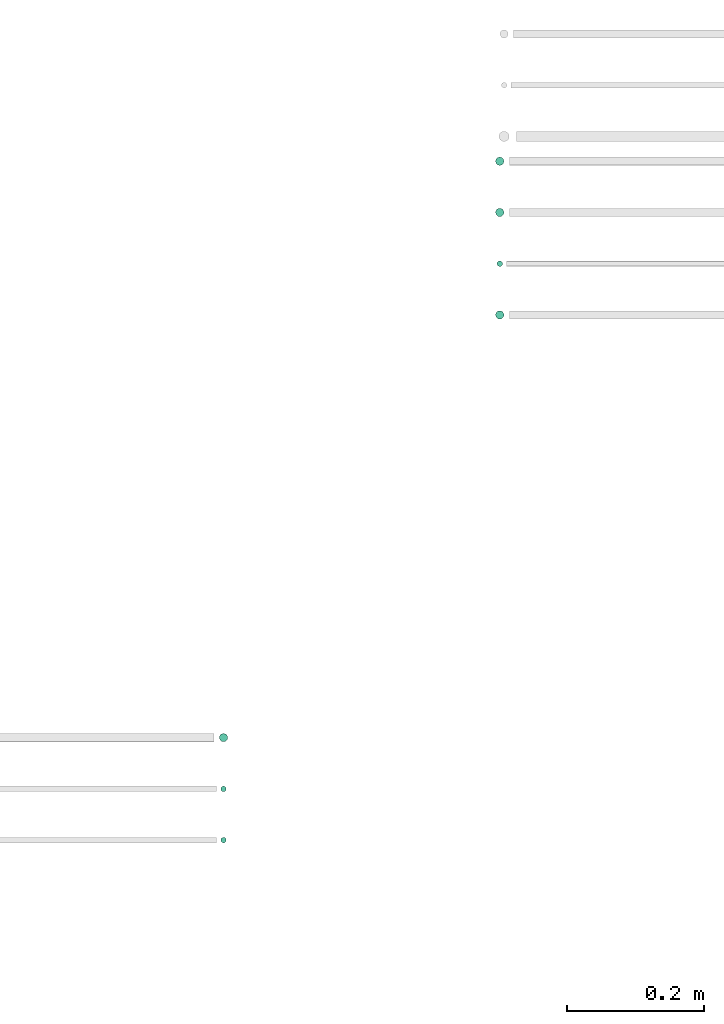
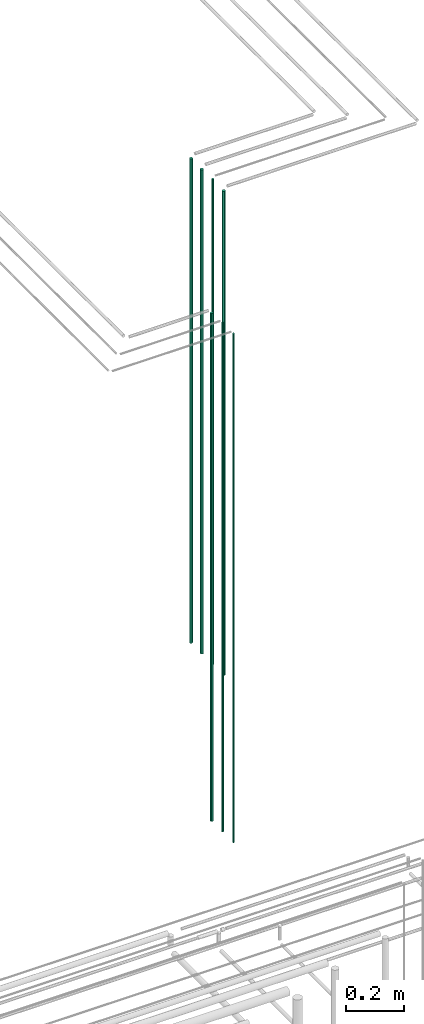
# One storey, part 67 of 331: 7 flow segments.
"""IFC2X3 building model written with IfcOpenShell, lengths in millimetres."""

from ifc_helpers import new_model, entity, si_unit, converted_unit, derived_unit, direction, frame, frame_2d, origin, origin_2d_with_axis, place, context, subcontext, project, spatial, circle, extrude, type_object, element, save


model = new_model("IFC2X3")

# Units and contexts
model_context = context("Model", 3, precision=0.01, world=origin(), true_north=direction((6.12303176911189e-17, 1.0)))
body_context = subcontext(model_context, "Body", "Model", "MODEL_VIEW")
ifc_project = project(units=[si_unit("LENGTHUNIT", "METRE", prefix="MILLI"), si_unit("AREAUNIT", "SQUARE_METRE"), si_unit("VOLUMEUNIT", "CUBIC_METRE"), converted_unit("PLANEANGLEUNIT", "DEGREE", entity("IfcRatioMeasure", 0.0174532925199433), si_unit("PLANEANGLEUNIT", "RADIAN"), dimensions=[0, 0, 0, 0, 0, 0, 0]), si_unit("MASSUNIT", "GRAM", prefix="KILO"), derived_unit("MASSDENSITYUNIT", [(si_unit("MASSUNIT", "GRAM", prefix="KILO"), 1), (si_unit("LENGTHUNIT", "METRE"), -3)]), derived_unit("MOMENTOFINERTIAUNIT", [(si_unit("LENGTHUNIT", "METRE"), 4)]), si_unit("TIMEUNIT", "SECOND"), si_unit("FREQUENCYUNIT", "HERTZ"), si_unit("THERMODYNAMICTEMPERATUREUNIT", "DEGREE_CELSIUS"), derived_unit("THERMALTRANSMITTANCEUNIT", [(si_unit("MASSUNIT", "GRAM", prefix="KILO"), 1), (si_unit("THERMODYNAMICTEMPERATUREUNIT", "KELVIN"), -1), (si_unit("TIMEUNIT", "SECOND"), -3)]), derived_unit("VOLUMETRICFLOWRATEUNIT", [(si_unit("LENGTHUNIT", "METRE"), 3), (si_unit("TIMEUNIT", "SECOND"), -1)]), derived_unit("MASSFLOWRATEUNIT", [(si_unit("MASSUNIT", "GRAM", prefix="KILO"), 1), (si_unit("TIMEUNIT", "SECOND"), -1)]), derived_unit("ROTATIONALFREQUENCYUNIT", [(si_unit("TIMEUNIT", "SECOND"), -1)]), si_unit("ELECTRICCURRENTUNIT", "AMPERE"), si_unit("ELECTRICVOLTAGEUNIT", "VOLT"), si_unit("POWERUNIT", "WATT"), si_unit("FORCEUNIT", "NEWTON", prefix="KILO"), si_unit("ILLUMINANCEUNIT", "LUX"), si_unit("LUMINOUSFLUXUNIT", "LUMEN"), si_unit("LUMINOUSINTENSITYUNIT", "CANDELA"), derived_unit("USERDEFINED", [(si_unit("MASSUNIT", "GRAM", prefix="KILO"), -1), (si_unit("LENGTHUNIT", "METRE"), -2), (si_unit("TIMEUNIT", "SECOND"), 3), (si_unit("LUMINOUSFLUXUNIT", "LUMEN"), 1)]), derived_unit("LINEARVELOCITYUNIT", [(si_unit("LENGTHUNIT", "METRE"), 1), (si_unit("TIMEUNIT", "SECOND"), -1)]), si_unit("PRESSUREUNIT", "PASCAL"), derived_unit("USERDEFINED", [(si_unit("LENGTHUNIT", "METRE"), -2), (si_unit("MASSUNIT", "GRAM", prefix="KILO"), 1), (si_unit("TIMEUNIT", "SECOND"), -2)]), derived_unit("LINEARFORCEUNIT", [(si_unit("MASSUNIT", "GRAM", prefix="KILO"), 1), (si_unit("LENGTHUNIT", "METRE"), 1), (si_unit("TIMEUNIT", "SECOND"), -2), (si_unit("LENGTHUNIT", "METRE"), -1)]), derived_unit("PLANARFORCEUNIT", [(si_unit("MASSUNIT", "GRAM", prefix="KILO"), 1), (si_unit("LENGTHUNIT", "METRE"), 1), (si_unit("TIMEUNIT", "SECOND"), -2), (si_unit("LENGTHUNIT", "METRE"), -2)])], contexts=[model_context])

# Site, building, storey
site_placement = place(None, frame((0.0, -0.00077364408347762, 0.0)))
site = spatial("IfcSite", under=ifc_project, at=site_placement, CompositionType="ELEMENT")
building_placement = place(site_placement, origin())
building = spatial("IfcBuilding", under=site, at=building_placement, CompositionType="ELEMENT")
storey_placement = place(building_placement, origin())
storey = spatial("IfcBuildingStorey", under=building, at=storey_placement, CompositionType="ELEMENT", Elevation=0.0)

# Flow segments
pipe_segment_type = type_object("IfcPipeSegmentType", PredefinedType="NOTDEFINED")
for number, where in (
    (1, (62762.1765027261, 2661.02529159145, 13090.0)),
    (2, (62762.1765027261, 2586.02529159145, 13090.0)),
):
    element("IfcFlowSegment", number, at=place(storey_placement, frame(where)), inside=storey, type_object=pipe_segment_type, context=body_context, shape_type="SweptSolid", body=[
        extrude(circle(Radius=6.0, at=origin_2d_with_axis()), frame((7.59527223591454, 7.59527223591616, 0.0)), (0.0, 0.0, 1.0), 2046.0),
    ])
flow_segment_1_placement = place(storey_placement, frame((62764.1765027261, 2513.02529159145, 13090.0)))
element("IfcFlowSegment", 3, at=flow_segment_1_placement, inside=storey, type_object=pipe_segment_type, context=body_context, shape_type="SweptSolid", body=[
    extrude(circle(Radius=4.0, at=origin_2d_with_axis()), frame((5.59527223591499, 5.59527223591607, 0.0)), (0.0, 0.0, 1.0), 2050.0),
])
flow_segment_2_placement = place(storey_placement, frame((62762.1765027261, 2436.02529159145, 13090.0)))
element("IfcFlowSegment", 4, at=flow_segment_2_placement, inside=storey, type_object=pipe_segment_type, context=body_context, shape_type="SweptSolid", body=[
    extrude(circle(Radius=6.0, at=origin_2d_with_axis()), frame((7.59527223591454, 7.59527223591616, 0.0)), (0.0, 0.0, 1.0), 2046.0),
])
flow_segment_3_placement = place(storey_placement, frame((62357.9067248113, 1817.40472776424, 12990.0)))
element("IfcFlowSegment", 5, at=flow_segment_3_placement, inside=storey, type_object=pipe_segment_type, context=body_context, shape_type="SweptSolid", body=[
    extrude(circle(Radius=6.0, at=origin_2d_with_axis()), frame((7.59527223591454, 7.59527223591589, 0.0)), (0.0, 0.0, 1.0), 2146.0),
])
for number, where in (
    (6, (62359.9067248113, 1744.40472776424, 12990.0)),
    (7, (62359.9067248113, 1669.40472776424, 12990.0)),
):
    element("IfcFlowSegment", number, at=place(storey_placement, frame(where)), inside=storey, type_object=pipe_segment_type, context=body_context, shape_type="SweptSolid", body=[
        extrude(circle(Radius=4.0, at=frame_2d((0.0, 2.70716782324598e-13), x_axis=(1.0, 0.0))), frame((5.59527223591499, 5.59527223591553, 0.0)), (0.0, 0.0, 1.0), 2150.00000000001),
    ])

save(model, "model.ifc")
